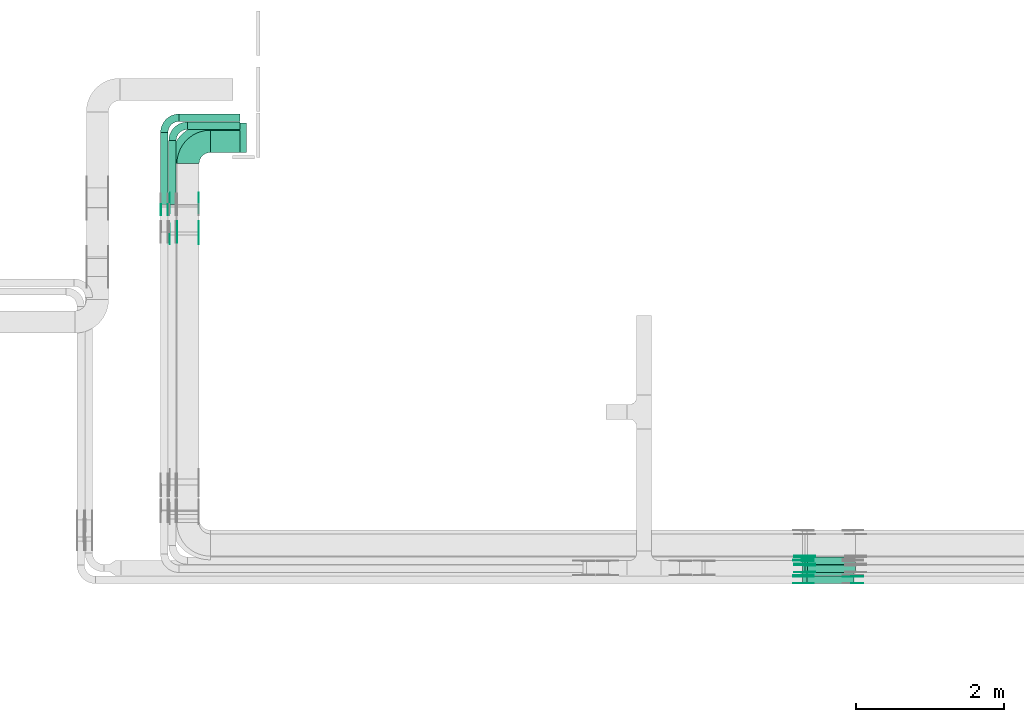
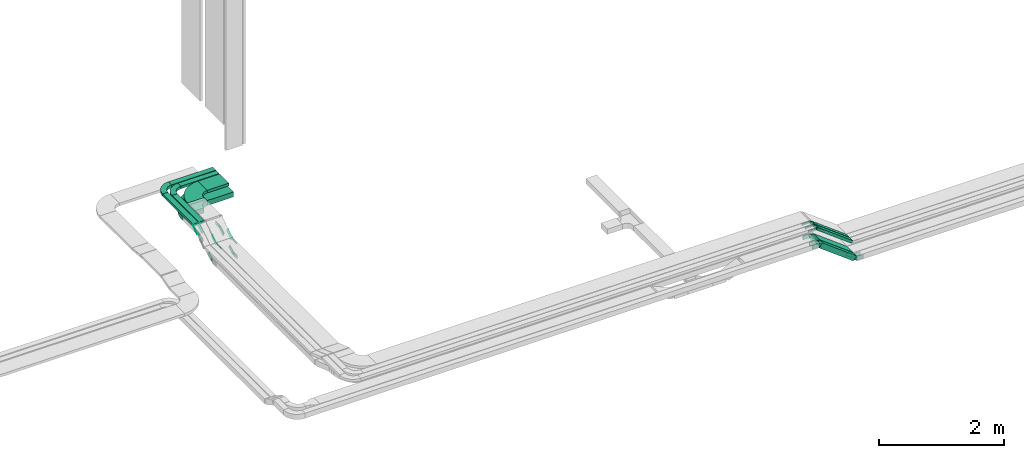
# One storey, part 8 of 27: 41 flow fittings, 10 flow segments.
"""IFC2X3 building model written with IfcOpenShell, lengths in millimetres."""

from ifc_helpers import new_model, entity, si_unit, converted_unit, derived_unit, direction, frame, frame_2d, origin, origin_2d_with_axis, place, context, subcontext, project, spatial, polyline, circle_curve, parameter, trimmed, segment, composite_curve, rectangle, outline, extrude, source, transform, mapped, material, type_object, type_shapes, element, save


model = new_model("IFC2X3")

# Units and contexts
model_context = context("Model", 3, precision=0.01, world=origin(), true_north=direction((6.12303176911189e-17, 1.0)))
body_context = subcontext(model_context, "Body", "Model", "MODEL_VIEW")
ifc_project = project(units=[si_unit("LENGTHUNIT", "METRE", prefix="MILLI"), si_unit("AREAUNIT", "SQUARE_METRE"), si_unit("VOLUMEUNIT", "CUBIC_METRE"), converted_unit("PLANEANGLEUNIT", "DEGREE", entity("IfcRatioMeasure", 0.0174532925199433), si_unit("PLANEANGLEUNIT", "RADIAN"), dimensions=[0, 0, 0, 0, 0, 0, 0]), si_unit("MASSUNIT", "GRAM", prefix="KILO"), derived_unit("MASSDENSITYUNIT", [(si_unit("MASSUNIT", "GRAM", prefix="KILO"), 1), (si_unit("LENGTHUNIT", "METRE"), -3)]), derived_unit("MOMENTOFINERTIAUNIT", [(si_unit("LENGTHUNIT", "METRE"), 4)]), si_unit("TIMEUNIT", "SECOND"), si_unit("FREQUENCYUNIT", "HERTZ"), si_unit("THERMODYNAMICTEMPERATUREUNIT", "DEGREE_CELSIUS"), derived_unit("THERMALTRANSMITTANCEUNIT", [(si_unit("MASSUNIT", "GRAM", prefix="KILO"), 1), (si_unit("THERMODYNAMICTEMPERATUREUNIT", "KELVIN"), -1), (si_unit("TIMEUNIT", "SECOND"), -3)]), derived_unit("VOLUMETRICFLOWRATEUNIT", [(si_unit("LENGTHUNIT", "METRE"), 3), (si_unit("TIMEUNIT", "SECOND"), -1)]), derived_unit("MASSFLOWRATEUNIT", [(si_unit("MASSUNIT", "GRAM", prefix="KILO"), 1), (si_unit("TIMEUNIT", "SECOND"), -1)]), derived_unit("ROTATIONALFREQUENCYUNIT", [(si_unit("TIMEUNIT", "SECOND"), -1)]), si_unit("ELECTRICCURRENTUNIT", "AMPERE"), si_unit("ELECTRICVOLTAGEUNIT", "VOLT"), si_unit("POWERUNIT", "WATT"), si_unit("FORCEUNIT", "NEWTON", prefix="KILO"), si_unit("ILLUMINANCEUNIT", "LUX"), si_unit("LUMINOUSFLUXUNIT", "LUMEN"), si_unit("LUMINOUSINTENSITYUNIT", "CANDELA"), derived_unit("USERDEFINED", [(si_unit("MASSUNIT", "GRAM", prefix="KILO"), -1), (si_unit("LENGTHUNIT", "METRE"), -2), (si_unit("TIMEUNIT", "SECOND"), 3), (si_unit("LUMINOUSFLUXUNIT", "LUMEN"), 1)]), derived_unit("LINEARVELOCITYUNIT", [(si_unit("LENGTHUNIT", "METRE"), 1), (si_unit("TIMEUNIT", "SECOND"), -1)]), si_unit("PRESSUREUNIT", "PASCAL"), derived_unit("USERDEFINED", [(si_unit("LENGTHUNIT", "METRE"), -2), (si_unit("MASSUNIT", "GRAM", prefix="KILO"), 1), (si_unit("TIMEUNIT", "SECOND"), -2)]), derived_unit("LINEARFORCEUNIT", [(si_unit("MASSUNIT", "GRAM", prefix="KILO"), 1), (si_unit("LENGTHUNIT", "METRE"), 1), (si_unit("TIMEUNIT", "SECOND"), -2), (si_unit("LENGTHUNIT", "METRE"), -1)]), derived_unit("PLANARFORCEUNIT", [(si_unit("MASSUNIT", "GRAM", prefix="KILO"), 1), (si_unit("LENGTHUNIT", "METRE"), 1), (si_unit("TIMEUNIT", "SECOND"), -2), (si_unit("LENGTHUNIT", "METRE"), -2)])], contexts=[model_context])

# Site, building, storey
site_placement = place(None, origin())
site = spatial("IfcSite", under=ifc_project, at=site_placement, CompositionType="ELEMENT")
building_placement = place(site_placement, origin())
building = spatial("IfcBuilding", under=site, at=building_placement, CompositionType="ELEMENT")
storey_placement = place(building_placement, origin())
storey = spatial("IfcBuildingStorey", under=building, at=storey_placement, CompositionType="ELEMENT", Elevation=0.0)

# Flow segments
cable_carrier_segment_type = type_object("IfcCableCarrierSegmentType", PredefinedType="CABLETRAYSEGMENT")
flow_segment_1_placement = place(storey_placement, frame((23829.86, 8250.0, 2621.54)))
element("IfcFlowSegment", 1, at=flow_segment_1_placement, inside=storey, type_object=cable_carrier_segment_type, context=body_context, shape_type="SweptSolid", body=[
    extrude(rectangle(XDim=100.000000000001, YDim=100.000000000001, at=frame_2d((0.0, 0.0), x_axis=(0.0, 1.0))), frame((30.09, 50.0, 516.98), z_axis=(0.79863551004726, 0.0, -0.601815023152092), x_axis=(0.0, 1.0, 0.0)), (0.0, 0.0, 1.0), 792.683776055081),
])
flow_segment_2_placement = place(storey_placement, frame((23829.86, 8360.0, 2621.54)))
element("IfcFlowSegment", 2, at=flow_segment_2_placement, inside=storey, type_object=cable_carrier_segment_type, context=body_context, shape_type="SweptSolid", body=[
    extrude(rectangle(XDim=99.9999999999992, YDim=200.0, at=frame_2d((0.0, 0.0), x_axis=(0.0, 1.0))), frame((30.09, 100.0, 516.98), z_axis=(0.798635510047449, 0.0, -0.601815023151841), x_axis=(0.0, 1.0, 0.0)), (0.0, 0.0, 1.0), 792.683776055017),
])
flow_segment_3_placement = place(storey_placement, frame((23864.5, 8400.0, 2861.48)))
element("IfcFlowSegment", 3, at=flow_segment_3_placement, inside=storey, type_object=cable_carrier_segment_type, context=body_context, shape_type="SweptSolid", body=[
    extrude(rectangle(XDim=49.9999999999957, YDim=100.000000000001, at=frame_2d((0.0, 0.0), x_axis=(0.0, 1.0))), frame((15.05, 50.0, 507.08), z_axis=(0.798635510047288, 0.0, -0.601815023152055), x_axis=(0.0, 1.0, 0.0)), (0.0, 0.0, 1.0), 809.413542030208),
])
flow_segment_4_placement = place(storey_placement, frame((23864.5, 8510.0, 2861.48)))
element("IfcFlowSegment", 4, at=flow_segment_4_placement, inside=storey, type_object=cable_carrier_segment_type, context=body_context, shape_type="SweptSolid", body=[
    extrude(rectangle(XDim=49.9999999999974, YDim=100.000000000001, at=frame_2d((0.0, 0.0), x_axis=(0.0, 1.0))), frame((15.05, 50.0, 507.08), z_axis=(0.798635510047365, 0.0, -0.601815023151953), x_axis=(0.0, 1.0, 0.0)), (0.0, 0.0, 1.0), 809.413542030358),
])
flow_segment_5_placement = place(storey_placement, frame((15851.0, 14057.56, 3450.0)))
element("IfcFlowSegment", 5, at=flow_segment_5_placement, inside=storey, type_object=cable_carrier_segment_type, context=body_context, shape_type="SweptSolid", body=[
    extrude(rectangle(XDim=399.000000000009, YDim=300.000000000001, at=origin_2d_with_axis()), frame((199.5, 150.0, 0.0)), (0.0, 0.0, 1.0), 49.9999999999989),
])
flow_segment_6_placement = place(storey_placement, frame((15290.0, 13356.57, 3450.0)))
element("IfcFlowSegment", 6, at=flow_segment_6_placement, inside=storey, type_object=cable_carrier_segment_type, context=body_context, shape_type="SweptSolid", body=[
    extrude(rectangle(XDim=859.993317234152, YDim=99.9999999999989, at=origin_2d_with_axis()), frame((50.0, 430.0, 0.0), z_axis=(0.0, 0.0, 1.0), x_axis=(0.0, 1.0, 0.0)), (0.0, 0.0, 1.0), 49.9999999999995),
])
flow_segment_7_placement = place(storey_placement, frame((15541.0, 14367.56, 3450.0)))
element("IfcFlowSegment", 7, at=flow_segment_7_placement, inside=storey, type_object=cable_carrier_segment_type, context=body_context, shape_type="SweptSolid", body=[
    extrude(rectangle(XDim=709.000000000006, YDim=99.9999999999989, at=origin_2d_with_axis()), frame((354.5, 50.0, 0.0)), (0.0, 0.0, 1.0), 49.9999999999995),
])
flow_segment_8_placement = place(storey_placement, frame((15180.0, 13356.57, 3450.0)))
element("IfcFlowSegment", 8, at=flow_segment_8_placement, inside=storey, type_object=cable_carrier_segment_type, context=body_context, shape_type="SweptSolid", body=[
    extrude(rectangle(XDim=969.993317234148, YDim=99.9999999999989, at=origin_2d_with_axis()), frame((50.0, 485.0, 0.0), z_axis=(0.0, 0.0, 1.0), x_axis=(0.0, 1.0, 0.0)), (0.0, 0.0, 1.0), 50.0),
])
flow_segment_9_placement = place(storey_placement, frame((15431.0, 14477.56, 3450.0)))
element("IfcFlowSegment", 9, at=flow_segment_9_placement, inside=storey, type_object=cable_carrier_segment_type, context=body_context, shape_type="SweptSolid", body=[
    extrude(rectangle(XDim=819.000000000007, YDim=99.9999999999989, at=origin_2d_with_axis()), frame((409.5, 50.0, 0.0)), (0.0, 0.0, 1.0), 49.9999999999995),
])
flow_segment_10_placement = place(storey_placement, frame((15851.0, 14057.56, 3200.0)))
element("IfcFlowSegment", 10, at=flow_segment_10_placement, inside=storey, type_object=cable_carrier_segment_type, context=body_context, shape_type="SweptSolid", body=[
    extrude(rectangle(XDim=489.000000000008, YDim=400.0, at=origin_2d_with_axis()), frame((244.5, 200.0, 0.0)), (0.0, 0.0, 1.0), 100.0),
])

# Flow fittings
ifc_material_1 = material()
cable_carrier_fitting_type_1 = type_object("IfcCableCarrierFittingType", Name="470_DKC_S5_Variable Angle Elbow 0-45:-", PredefinedType="NOTDEFINED", material=ifc_material_1)
shared_shape_1 = source(origin(), body_context, "Body", "SweptSolid", [
    extrude(outline(composite_curve([segment(polyline([(-150.75, -300.25), (-149.75, -300.25)]), True, "CONTINUOUS"), segment(trimmed(circle_curve(frame_2d((-149.75, 149.75), x_axis=(0.0, -1.0)), 450.0), [parameter(0.0)], [parameter(90.0000000000001)], True, "PARAMETER"), True, "CONTINUOUS"), segment(polyline([(300.25, 149.75), (300.25, 150.75)]), True, "CONTINUOUS"), segment(polyline([(300.25, 150.75), (0.25, 150.75)]), True, "CONTINUOUS"), segment(polyline([(0.25, 150.75), (0.25, 149.75)]), True, "CONTINUOUS"), segment(trimmed(circle_curve(frame_2d((-149.75, 149.75), x_axis=(0.0, -1.0)), 150.0), [parameter(0.0)], [parameter(90.0000000000001)], True, "PARAMETER"), False, "CONTINUOUS"), segment(polyline([(-149.75, -0.25), (-150.75, -0.25)]), True, "CONTINUOUS"), segment(polyline([(-150.75, -0.25), (-150.75, -300.25)]), True, "CONTINUOUS")], self_intersect=False)), frame((-150.25, 150.25, -25.0)), (0.0, 0.0, 1.0), 49.9999999999974),
])
type_shapes(cable_carrier_fitting_type_1, [shared_shape_1])
flow_fitting_1_placement = place(storey_placement, frame((15550.0, 14207.56, 3475.0), z_axis=(0.0, 0.0, 1.0), x_axis=(-1.0, 0.0, 0.0)))
element("IfcFlowFitting", 11, at=flow_fitting_1_placement, inside=storey, type_object=cable_carrier_fitting_type_1, material=ifc_material_1, Name="470_DKC_S5_Variable Angle Elbow 0-45:-", ObjectType="470_DKC_S5_Variable Angle Elbow 0-45:-", context=body_context, shape_type="MappedRepresentation", body=[
    mapped(shared_shape_1, transform((0.0, 0.0, 0.0), scale=1.0)),
])
cable_carrier_fitting_type_2 = type_object("IfcCableCarrierFittingType", Name="470_DKC_S5_Variable Angle Elbow 0-45:-", PredefinedType="NOTDEFINED", material=ifc_material_1)
shared_shape_2 = source(origin(), body_context, "Body", "SweptSolid", [
    extrude(outline(composite_curve([segment(polyline([(-100.75, -150.25), (-99.75, -150.25)]), True, "CONTINUOUS"), segment(trimmed(circle_curve(frame_2d((-99.75, 99.75), x_axis=(0.0, -1.0)), 250.0), [parameter(0.0)], [parameter(90.0000000000001)], True, "PARAMETER"), True, "CONTINUOUS"), segment(polyline([(150.25, 99.75), (150.25, 100.75)]), True, "CONTINUOUS"), segment(polyline([(150.25, 100.75), (50.25, 100.75)]), True, "CONTINUOUS"), segment(polyline([(50.25, 100.75), (50.25, 99.75)]), True, "CONTINUOUS"), segment(trimmed(circle_curve(frame_2d((-99.75, 99.75), x_axis=(0.0, -1.0)), 150.0), [parameter(0.0)], [parameter(90.0000000000001)], True, "PARAMETER"), False, "CONTINUOUS"), segment(polyline([(-99.75, -50.25), (-100.75, -50.25)]), True, "CONTINUOUS"), segment(polyline([(-100.75, -50.25), (-100.75, -150.25)]), True, "CONTINUOUS")], self_intersect=False)), frame((-100.25, 100.25, -25.0)), (0.0, 0.0, 1.0), 49.9999999999997),
])
type_shapes(cable_carrier_fitting_type_2, [shared_shape_2])
for number, where, z_axis, x_axis, name in (
    (12, (15340.0, 14417.56, 3475.0), (0.0, 0.0, 1.0), (-1.0, 0.0, 0.0), "470_DKC_S5_Variable Angle Elbow 0-45:-"),
    (13, (15230.0, 14527.56, 3475.0), (0.0, 0.0, 1.0), (-1.0, 0.0, 0.0), "470_DKC_S5_Variable Angle Elbow 0-45:-"),
):
    element("IfcFlowFitting", number, at=place(storey_placement, frame(where, z_axis=z_axis, x_axis=x_axis)), inside=storey, type_object=cable_carrier_fitting_type_2, material=ifc_material_1, Name=name, ObjectType="470_DKC_S5_Variable Angle Elbow 0-45:-", context=body_context, shape_type="MappedRepresentation", body=[
        mapped(shared_shape_2, transform((0.0, 0.0, 0.0), scale=1.0)),
    ])
ifc_material_2 = material(Name="G")
cable_carrier_fitting_type_3 = type_object("IfcCableCarrierFittingType", PredefinedType="NOTDEFINED", material=ifc_material_2)
shared_shape_3 = source(origin(), body_context, "Body", "SweptSolid", [
    extrude(outline(composite_curve([segment(trimmed(circle_curve(frame_2d((-44.59, 0.0), x_axis=(1.0, 0.0)), 12.5), [parameter(90.0000000000007)], [parameter(270.0)], True, "PARAMETER"), True, "CONTINUOUS"), segment(polyline([(-44.59, -12.5), (-33.09, -12.5)]), True, "CONTINUOUS"), segment(polyline([(-33.09, -12.5), (-31.23, -14.5)]), True, "CONTINUOUS"), segment(polyline([(-31.23, -14.5), (108.91, -14.5)]), True, "CONTINUOUS"), segment(polyline([(108.91, -14.5), (108.91, 14.5)]), True, "CONTINUOUS"), segment(polyline([(108.91, 14.5), (-31.23, 14.5)]), True, "CONTINUOUS"), segment(polyline([(-31.23, 14.5), (-33.09, 12.5)]), True, "CONTINUOUS"), segment(polyline([(-33.09, 12.5), (-44.59, 12.5)]), True, "CONTINUOUS")], self_intersect=False)), frame((44.59, 0.0, 0.0), z_axis=(0.0, 0.0, -1.0), x_axis=(1.0, 0.0, 0.0)), (0.0, 0.0, -1.0), 2.0),
])
type_shapes(cable_carrier_fitting_type_3, [shared_shape_3])
flow_fitting_2_placement = place(storey_placement, frame((15273.46, 13347.25, 3475.0), z_axis=(1.0, 0.0, 0.0), x_axis=(0.0, -0.848048096156981, -0.529919264232316)))
element("IfcFlowFitting", 14, at=flow_fitting_2_placement, inside=storey, type_object=cable_carrier_fitting_type_3, material=ifc_material_2, context=body_context, shape_type="MappedRepresentation", body=[
    mapped(shared_shape_3, transform((0.0, 0.0, 0.0), scale=1.0)),
])
cable_carrier_fitting_type_4 = type_object("IfcCableCarrierFittingType", PredefinedType="NOTDEFINED", material=ifc_material_2)
type_shapes(cable_carrier_fitting_type_4, [shared_shape_3])
flow_fitting_3_placement = place(storey_placement, frame((15404.54, 12995.18, 3255.0), z_axis=(-1.0, 0.0, 0.0), x_axis=(0.0, -1.0, 0.0)))
element("IfcFlowFitting", 15, at=flow_fitting_3_placement, inside=storey, type_object=cable_carrier_fitting_type_4, material=ifc_material_2, context=body_context, shape_type="MappedRepresentation", body=[
    mapped(shared_shape_3, transform((0.0, 0.0, 0.0), scale=1.0)),
])
flow_fitting_4_placement = place(storey_placement, frame((15693.46, 12995.18, 3255.0), z_axis=(1.0, 0.0, 0.0), x_axis=(0.0, 0.848048096156905, 0.529919264232438)))
element("IfcFlowFitting", 16, at=flow_fitting_4_placement, inside=storey, type_object=cable_carrier_fitting_type_3, material=ifc_material_2, context=body_context, shape_type="MappedRepresentation", body=[
    mapped(shared_shape_3, transform((0.0, 0.0, 0.0), scale=1.0)),
])
for number, where, z_axis, x_axis in (
    (17, (23871.0, 8624.54, 3375.0), (0.0, -1.0, 0.0), (-1.0, 0.0, 0.0)),
    (18, (23871.0, 8514.54, 3375.0), (0.0, -1.0, 0.0), (-1.0, 0.0, 0.0)),
):
    element("IfcFlowFitting", number, at=place(storey_placement, frame(where, z_axis=z_axis, x_axis=x_axis)), inside=storey, type_object=cable_carrier_fitting_type_4, material=ifc_material_2, context=body_context, shape_type="MappedRepresentation", body=[
        mapped(shared_shape_3, transform((0.0, 0.0, 0.0), scale=1.0)),
    ])
flow_fitting_5_placement = place(storey_placement, frame((23871.0, 8603.46, 3375.0), z_axis=(0.0, 1.0, 0.0), x_axis=(0.798635510047374, 0.0, -0.601815023151941)))
element("IfcFlowFitting", 19, at=flow_fitting_5_placement, inside=storey, type_object=cable_carrier_fitting_type_3, material=ifc_material_2, context=body_context, shape_type="MappedRepresentation", body=[
    mapped(shared_shape_3, transform((0.0, 0.0, 0.0), scale=1.0)),
])
flow_fitting_6_placement = place(storey_placement, frame((23871.0, 8404.54, 3375.0), z_axis=(0.0, -1.0, 0.0), x_axis=(-1.0, 0.0, 0.0)))
element("IfcFlowFitting", 20, at=flow_fitting_6_placement, inside=storey, type_object=cable_carrier_fitting_type_4, material=ifc_material_2, context=body_context, shape_type="MappedRepresentation", body=[
    mapped(shared_shape_3, transform((0.0, 0.0, 0.0), scale=1.0)),
])
flow_fitting_7_placement = place(storey_placement, frame((23871.0, 8493.46, 3375.0), z_axis=(0.0, 1.0, 0.0), x_axis=(0.798635510047285, 0.0, -0.601815023152059)))
element("IfcFlowFitting", 21, at=flow_fitting_7_placement, inside=storey, type_object=cable_carrier_fitting_type_3, material=ifc_material_2, context=body_context, shape_type="MappedRepresentation", body=[
    mapped(shared_shape_3, transform((0.0, 0.0, 0.0), scale=1.0)),
])
cable_carrier_fitting_type_5 = type_object("IfcCableCarrierFittingType", PredefinedType="NOTDEFINED", material=ifc_material_2)
shared_shape_4 = source(origin(), body_context, "Body", "SweptSolid", [
    extrude(outline(composite_curve([segment(trimmed(circle_curve(frame_2d((-44.59, 0.0), x_axis=(1.0, 0.0)), 12.5), [parameter(90.0000000000007)], [parameter(270.0)], True, "PARAMETER"), True, "CONTINUOUS"), segment(polyline([(-44.59, -12.5), (-33.09, -12.5)]), True, "CONTINUOUS"), segment(polyline([(-33.09, -12.5), (-31.23, -14.5)]), True, "CONTINUOUS"), segment(polyline([(-31.23, -14.5), (108.91, -14.5)]), True, "CONTINUOUS"), segment(polyline([(108.91, -14.5), (108.91, 14.5)]), True, "CONTINUOUS"), segment(polyline([(108.91, 14.5), (-31.23, 14.5)]), True, "CONTINUOUS"), segment(polyline([(-31.23, 14.5), (-33.09, 12.5)]), True, "CONTINUOUS"), segment(polyline([(-33.09, 12.5), (-44.59, 12.5)]), True, "CONTINUOUS")], self_intersect=False)), frame((44.59, 0.0, 0.0)), (0.0, 0.0, 1.0), 2.0),
])
type_shapes(cable_carrier_fitting_type_5, [shared_shape_4])
flow_fitting_8_placement = place(storey_placement, frame((15186.54, 13347.25, 3475.0), z_axis=(-1.0, 0.0, 0.0), x_axis=(0.0, -0.848048096156981, -0.529919264232316)))
element("IfcFlowFitting", 22, at=flow_fitting_8_placement, inside=storey, type_object=cable_carrier_fitting_type_5, material=ifc_material_2, context=body_context, shape_type="MappedRepresentation", body=[
    mapped(shared_shape_4, transform((0.0, 0.0, 0.0), scale=1.0)),
])
cable_carrier_fitting_type_6 = type_object("IfcCableCarrierFittingType", PredefinedType="NOTDEFINED", material=ifc_material_2)
type_shapes(cable_carrier_fitting_type_6, [shared_shape_4])
flow_fitting_9_placement = place(storey_placement, frame((15695.46, 12995.18, 3255.0), z_axis=(1.0, 0.0, 0.0), x_axis=(0.0, -1.0, 0.0)))
element("IfcFlowFitting", 23, at=flow_fitting_9_placement, inside=storey, type_object=cable_carrier_fitting_type_6, material=ifc_material_2, context=body_context, shape_type="MappedRepresentation", body=[
    mapped(shared_shape_4, transform((0.0, 0.0, 0.0), scale=1.0)),
])
for number, where, z_axis, x_axis in (
    (24, (15406.54, 12995.18, 3255.0), (-1.0, 0.0, 0.0), (0.0, 0.848048096156905, 0.529919264232438)),
    (25, (23871.0, 8626.54, 3375.0), (0.0, -1.0, 0.0), (0.798635510047512, 0.0, -0.601815023151758)),
):
    element("IfcFlowFitting", number, at=place(storey_placement, frame(where, z_axis=z_axis, x_axis=x_axis)), inside=storey, type_object=cable_carrier_fitting_type_5, material=ifc_material_2, context=body_context, shape_type="MappedRepresentation", body=[
        mapped(shared_shape_4, transform((0.0, 0.0, 0.0), scale=1.0)),
    ])
flow_fitting_10_placement = place(storey_placement, frame((23871.0, 8605.46, 3375.0), z_axis=(0.0, 1.0, 0.0), x_axis=(-1.0, 0.0, 0.0)))
element("IfcFlowFitting", 26, at=flow_fitting_10_placement, inside=storey, type_object=cable_carrier_fitting_type_6, material=ifc_material_2, context=body_context, shape_type="MappedRepresentation", body=[
    mapped(shared_shape_4, transform((0.0, 0.0, 0.0), scale=1.0)),
])
flow_fitting_11_placement = place(storey_placement, frame((23871.0, 8516.54, 3375.0), z_axis=(0.0, -1.0, 0.0), x_axis=(0.798635510047374, 0.0, -0.601815023151941)))
element("IfcFlowFitting", 27, at=flow_fitting_11_placement, inside=storey, type_object=cable_carrier_fitting_type_5, material=ifc_material_2, context=body_context, shape_type="MappedRepresentation", body=[
    mapped(shared_shape_4, transform((0.0, 0.0, 0.0), scale=1.0)),
])
flow_fitting_12_placement = place(storey_placement, frame((23871.0, 8495.46, 3375.0), z_axis=(0.0, 1.0, 0.0), x_axis=(-1.0, 0.0, 0.0)))
element("IfcFlowFitting", 28, at=flow_fitting_12_placement, inside=storey, type_object=cable_carrier_fitting_type_6, material=ifc_material_2, context=body_context, shape_type="MappedRepresentation", body=[
    mapped(shared_shape_4, transform((0.0, 0.0, 0.0), scale=1.0)),
])
flow_fitting_13_placement = place(storey_placement, frame((23871.0, 8406.54, 3375.0), z_axis=(0.0, -1.0, 0.0), x_axis=(0.798635510047285, 0.0, -0.601815023152059)))
element("IfcFlowFitting", 29, at=flow_fitting_13_placement, inside=storey, type_object=cable_carrier_fitting_type_5, material=ifc_material_2, context=body_context, shape_type="MappedRepresentation", body=[
    mapped(shared_shape_4, transform((0.0, 0.0, 0.0), scale=1.0)),
])
cable_carrier_fitting_type_7 = type_object("IfcCableCarrierFittingType", PredefinedType="NOTDEFINED", material=ifc_material_2)
shared_shape_5 = source(origin(), body_context, "Body", "SweptSolid", [
    extrude(outline(composite_curve([segment(trimmed(circle_curve(frame_2d((-41.47, 0.0), x_axis=(1.0, 0.0)), 25.0), [parameter(90.0000000000007)], [parameter(270.0)], True, "PARAMETER"), True, "CONTINUOUS"), segment(polyline([(-41.47, -25.0), (-29.97, -25.0)]), True, "CONTINUOUS"), segment(polyline([(-29.97, -25.0), (-28.1, -38.5)]), True, "CONTINUOUS"), segment(polyline([(-28.1, -38.5), (99.53, -38.5)]), True, "CONTINUOUS"), segment(polyline([(99.53, -38.5), (99.53, 38.5)]), True, "CONTINUOUS"), segment(polyline([(99.53, 38.5), (-28.1, 38.5)]), True, "CONTINUOUS"), segment(polyline([(-28.1, 38.5), (-29.97, 25.0)]), True, "CONTINUOUS"), segment(polyline([(-29.97, 25.0), (-41.47, 25.0)]), True, "CONTINUOUS")], self_intersect=False)), frame((41.47, 0.0, 0.0), z_axis=(0.0, 0.0, -1.0), x_axis=(1.0, 0.0, 0.0)), (0.0, 0.0, -1.0), 2.0),
])
type_shapes(cable_carrier_fitting_type_7, [shared_shape_5])
flow_fitting_14_placement = place(storey_placement, frame((23844.72, 8345.46, 3150.0), z_axis=(0.0, 1.0, 0.0), x_axis=(0.798635510047293, 0.0, -0.601815023152048)))
element("IfcFlowFitting", 30, at=flow_fitting_14_placement, inside=storey, type_object=cable_carrier_fitting_type_7, material=ifc_material_2, context=body_context, shape_type="MappedRepresentation", body=[
    mapped(shared_shape_5, transform((0.0, 0.0, 0.0), scale=1.0)),
])
cable_carrier_fitting_type_8 = type_object("IfcCableCarrierFittingType", PredefinedType="NOTDEFINED", material=ifc_material_2)
type_shapes(cable_carrier_fitting_type_8, [shared_shape_5])
flow_fitting_15_placement = place(storey_placement, frame((23844.72, 8256.54, 3150.0), z_axis=(0.0, -1.0, 0.0), x_axis=(-1.0, 0.0, 0.0)))
element("IfcFlowFitting", 31, at=flow_fitting_15_placement, inside=storey, type_object=cable_carrier_fitting_type_8, material=ifc_material_2, context=body_context, shape_type="MappedRepresentation", body=[
    mapped(shared_shape_5, transform((0.0, 0.0, 0.0), scale=1.0)),
])
flow_fitting_16_placement = place(storey_placement, frame((24508.25, 8254.54, 2650.0), z_axis=(0.0, -1.0, 0.0), x_axis=(1.0, 0.0, 0.0)))
element("IfcFlowFitting", 32, at=flow_fitting_16_placement, inside=storey, type_object=cable_carrier_fitting_type_7, material=ifc_material_2, context=body_context, shape_type="MappedRepresentation", body=[
    mapped(shared_shape_5, transform((0.0, 0.0, 0.0), scale=1.0)),
])
flow_fitting_17_placement = place(storey_placement, frame((24508.25, 8343.46, 2650.0), z_axis=(0.0, 1.0, 0.0), x_axis=(-0.79863551004728, 0.0, 0.601815023152065)))
element("IfcFlowFitting", 33, at=flow_fitting_17_placement, inside=storey, type_object=cable_carrier_fitting_type_8, material=ifc_material_2, context=body_context, shape_type="MappedRepresentation", body=[
    mapped(shared_shape_5, transform((0.0, 0.0, 0.0), scale=1.0)),
])
for number, where, z_axis, x_axis in (
    (34, (23844.72, 8574.54, 3150.0), (0.0, -1.0, 0.0), (-1.0, 0.0, 0.0)),
    (35, (23844.72, 8364.54, 3150.0), (0.0, -1.0, 0.0), (-1.0, 0.0, 0.0)),
):
    element("IfcFlowFitting", number, at=place(storey_placement, frame(where, z_axis=z_axis, x_axis=x_axis)), inside=storey, type_object=cable_carrier_fitting_type_7, material=ifc_material_2, context=body_context, shape_type="MappedRepresentation", body=[
        mapped(shared_shape_5, transform((0.0, 0.0, 0.0), scale=1.0)),
    ])
flow_fitting_18_placement = place(storey_placement, frame((23844.72, 8553.46, 3150.0), z_axis=(0.0, 1.0, 0.0), x_axis=(0.798635510047463, 0.0, -0.601815023151822)))
element("IfcFlowFitting", 36, at=flow_fitting_18_placement, inside=storey, type_object=cable_carrier_fitting_type_8, material=ifc_material_2, context=body_context, shape_type="MappedRepresentation", body=[
    mapped(shared_shape_5, transform((0.0, 0.0, 0.0), scale=1.0)),
])
flow_fitting_19_placement = place(storey_placement, frame((15304.54, 13377.15, 3250.0), z_axis=(-1.0, 0.0, 0.0), x_axis=(0.0, 1.0, 0.0)))
element("IfcFlowFitting", 37, at=flow_fitting_19_placement, inside=storey, type_object=cable_carrier_fitting_type_7, material=ifc_material_2, context=body_context, shape_type="MappedRepresentation", body=[
    mapped(shared_shape_5, transform((0.0, 0.0, 0.0), scale=1.0)),
])
flow_fitting_20_placement = place(storey_placement, frame((15693.46, 13377.15, 3250.0), z_axis=(1.0, 0.0, 0.0), x_axis=(0.0, -0.848048096156376, -0.529919264233284)))
element("IfcFlowFitting", 38, at=flow_fitting_20_placement, inside=storey, type_object=cable_carrier_fitting_type_8, material=ifc_material_2, context=body_context, shape_type="MappedRepresentation", body=[
    mapped(shared_shape_5, transform((0.0, 0.0, 0.0), scale=1.0)),
])
flow_fitting_21_placement = place(storey_placement, frame((15304.54, 12961.07, 2990.0), z_axis=(-1.0, 0.0, 0.0), x_axis=(0.0, -1.0, 0.0)))
element("IfcFlowFitting", 39, at=flow_fitting_21_placement, inside=storey, type_object=cable_carrier_fitting_type_7, material=ifc_material_2, context=body_context, shape_type="MappedRepresentation", body=[
    mapped(shared_shape_5, transform((0.0, 0.0, 0.0), scale=1.0)),
])
flow_fitting_22_placement = place(storey_placement, frame((15693.46, 12961.07, 2990.0), z_axis=(1.0, 0.0, 0.0), x_axis=(0.0, 0.848048096156366, 0.529919264233302)))
element("IfcFlowFitting", 40, at=flow_fitting_22_placement, inside=storey, type_object=cable_carrier_fitting_type_8, material=ifc_material_2, context=body_context, shape_type="MappedRepresentation", body=[
    mapped(shared_shape_5, transform((0.0, 0.0, 0.0), scale=1.0)),
])
cable_carrier_fitting_type_9 = type_object("IfcCableCarrierFittingType", PredefinedType="NOTDEFINED", material=ifc_material_2)
shared_shape_6 = source(origin(), body_context, "Body", "SweptSolid", [
    extrude(outline(composite_curve([segment(trimmed(circle_curve(frame_2d((-41.47, 0.0), x_axis=(1.0, 0.0)), 25.0), [parameter(90.0000000000007)], [parameter(270.0)], True, "PARAMETER"), True, "CONTINUOUS"), segment(polyline([(-41.47, -25.0), (-29.97, -25.0)]), True, "CONTINUOUS"), segment(polyline([(-29.97, -25.0), (-28.1, -38.5)]), True, "CONTINUOUS"), segment(polyline([(-28.1, -38.5), (99.53, -38.5)]), True, "CONTINUOUS"), segment(polyline([(99.53, -38.5), (99.53, 38.5)]), True, "CONTINUOUS"), segment(polyline([(99.53, 38.5), (-28.1, 38.5)]), True, "CONTINUOUS"), segment(polyline([(-28.1, 38.5), (-29.97, 25.0)]), True, "CONTINUOUS"), segment(polyline([(-29.97, 25.0), (-41.47, 25.0)]), True, "CONTINUOUS")], self_intersect=False)), frame((41.47, 0.0, 0.0)), (0.0, 0.0, 1.0), 2.0),
])
type_shapes(cable_carrier_fitting_type_9, [shared_shape_6])
flow_fitting_23_placement = place(storey_placement, frame((23844.72, 8254.54, 3150.0), z_axis=(0.0, -1.0, 0.0), x_axis=(0.798635510047293, 0.0, -0.601815023152048)))
element("IfcFlowFitting", 41, at=flow_fitting_23_placement, inside=storey, type_object=cable_carrier_fitting_type_9, material=ifc_material_2, context=body_context, shape_type="MappedRepresentation", body=[
    mapped(shared_shape_6, transform((0.0, 0.0, 0.0), scale=1.0)),
])
cable_carrier_fitting_type_10 = type_object("IfcCableCarrierFittingType", PredefinedType="NOTDEFINED", material=ifc_material_2)
type_shapes(cable_carrier_fitting_type_10, [shared_shape_6])
flow_fitting_24_placement = place(storey_placement, frame((23844.72, 8343.46, 3150.0), z_axis=(0.0, 1.0, 0.0), x_axis=(-1.0, 0.0, 0.0)))
element("IfcFlowFitting", 42, at=flow_fitting_24_placement, inside=storey, type_object=cable_carrier_fitting_type_10, material=ifc_material_2, context=body_context, shape_type="MappedRepresentation", body=[
    mapped(shared_shape_6, transform((0.0, 0.0, 0.0), scale=1.0)),
])
flow_fitting_25_placement = place(storey_placement, frame((24508.25, 8345.46, 2650.0), z_axis=(0.0, 1.0, 0.0), x_axis=(1.0, 0.0, 0.0)))
element("IfcFlowFitting", 43, at=flow_fitting_25_placement, inside=storey, type_object=cable_carrier_fitting_type_9, material=ifc_material_2, context=body_context, shape_type="MappedRepresentation", body=[
    mapped(shared_shape_6, transform((0.0, 0.0, 0.0), scale=1.0)),
])
flow_fitting_26_placement = place(storey_placement, frame((23844.72, 8576.54, 3150.0), z_axis=(0.0, -1.0, 0.0), x_axis=(0.798635510047464, 0.0, -0.601815023151821)))
element("IfcFlowFitting", 44, at=flow_fitting_26_placement, inside=storey, type_object=cable_carrier_fitting_type_10, material=ifc_material_2, context=body_context, shape_type="MappedRepresentation", body=[
    mapped(shared_shape_6, transform((0.0, 0.0, 0.0), scale=1.0)),
])
flow_fitting_27_placement = place(storey_placement, frame((23844.72, 8555.46, 3150.0), z_axis=(0.0, 1.0, 0.0), x_axis=(-1.0, 0.0, 0.0)))
element("IfcFlowFitting", 45, at=flow_fitting_27_placement, inside=storey, type_object=cable_carrier_fitting_type_9, material=ifc_material_2, context=body_context, shape_type="MappedRepresentation", body=[
    mapped(shared_shape_6, transform((0.0, 0.0, 0.0), scale=1.0)),
])
flow_fitting_28_placement = place(storey_placement, frame((23844.72, 8366.54, 3150.0), z_axis=(0.0, -1.0, 0.0), x_axis=(0.798635510047463, 0.0, -0.601815023151822)))
element("IfcFlowFitting", 46, at=flow_fitting_28_placement, inside=storey, type_object=cable_carrier_fitting_type_10, material=ifc_material_2, context=body_context, shape_type="MappedRepresentation", body=[
    mapped(shared_shape_6, transform((0.0, 0.0, 0.0), scale=1.0)),
])
flow_fitting_29_placement = place(storey_placement, frame((15695.46, 13377.15, 3250.0), z_axis=(1.0, 0.0, 0.0), x_axis=(0.0, 1.0, 0.0)))
element("IfcFlowFitting", 47, at=flow_fitting_29_placement, inside=storey, type_object=cable_carrier_fitting_type_9, material=ifc_material_2, context=body_context, shape_type="MappedRepresentation", body=[
    mapped(shared_shape_6, transform((0.0, 0.0, 0.0), scale=1.0)),
])
flow_fitting_30_placement = place(storey_placement, frame((15306.54, 13377.15, 3250.0), z_axis=(-1.0, 0.0, 0.0), x_axis=(0.0, -0.848048096156376, -0.529919264233284)))
element("IfcFlowFitting", 48, at=flow_fitting_30_placement, inside=storey, type_object=cable_carrier_fitting_type_10, material=ifc_material_2, context=body_context, shape_type="MappedRepresentation", body=[
    mapped(shared_shape_6, transform((0.0, 0.0, 0.0), scale=1.0)),
])
flow_fitting_31_placement = place(storey_placement, frame((15695.46, 12961.07, 2990.0), z_axis=(1.0, 0.0, 0.0), x_axis=(0.0, -1.0, 0.0)))
element("IfcFlowFitting", 49, at=flow_fitting_31_placement, inside=storey, type_object=cable_carrier_fitting_type_9, material=ifc_material_2, context=body_context, shape_type="MappedRepresentation", body=[
    mapped(shared_shape_6, transform((0.0, 0.0, 0.0), scale=1.0)),
])
flow_fitting_32_placement = place(storey_placement, frame((15306.54, 12961.07, 2990.0), z_axis=(-1.0, 0.0, 0.0), x_axis=(0.0, 0.848048096156366, 0.529919264233302)))
element("IfcFlowFitting", 50, at=flow_fitting_32_placement, inside=storey, type_object=cable_carrier_fitting_type_10, material=ifc_material_2, context=body_context, shape_type="MappedRepresentation", body=[
    mapped(shared_shape_6, transform((0.0, 0.0, 0.0), scale=1.0)),
])
cable_carrier_fitting_type_11 = type_object("IfcCableCarrierFittingType", Name="470_DKC_S5_Variable Angle Elbow 0-45:-", PredefinedType="NOTDEFINED", material=ifc_material_1)
shared_shape_7 = source(origin(), body_context, "Body", "SweptSolid", [
    extrude(outline(composite_curve([segment(polyline([(-175.75, -375.25), (-174.75, -375.25)]), True, "CONTINUOUS"), segment(trimmed(circle_curve(frame_2d((-174.75, 174.75), x_axis=(0.0, -1.0)), 550.0), [parameter(0.0)], [parameter(90.0)], True, "PARAMETER"), True, "CONTINUOUS"), segment(polyline([(375.25, 174.75), (375.25, 175.75)]), True, "CONTINUOUS"), segment(polyline([(375.25, 175.75), (-24.75, 175.75)]), True, "CONTINUOUS"), segment(polyline([(-24.75, 175.75), (-24.75, 174.75)]), True, "CONTINUOUS"), segment(trimmed(circle_curve(frame_2d((-174.75, 174.75), x_axis=(0.0, -1.0)), 150.0), [parameter(0.0)], [parameter(90.0)], True, "PARAMETER"), False, "CONTINUOUS"), segment(polyline([(-174.75, 24.75), (-175.75, 24.75)]), True, "CONTINUOUS"), segment(polyline([(-175.75, 24.75), (-175.75, -375.25)]), True, "CONTINUOUS")], self_intersect=False)), frame((-175.25, 175.25, -50.0)), (0.0, 0.0, 1.0), 99.9999999999956),
])
type_shapes(cable_carrier_fitting_type_11, [shared_shape_7])
flow_fitting_33_placement = place(storey_placement, frame((15500.0, 14257.56, 3250.0), z_axis=(0.0, 0.0, 1.0), x_axis=(-1.0, 0.0, 0.0)))
element("IfcFlowFitting", 51, at=flow_fitting_33_placement, inside=storey, type_object=cable_carrier_fitting_type_11, material=ifc_material_1, Name="470_DKC_S5_Variable Angle Elbow 0-45:-", ObjectType="470_DKC_S5_Variable Angle Elbow 0-45:-", context=body_context, shape_type="MappedRepresentation", body=[
    mapped(shared_shape_7, transform((0.0, 0.0, 0.0), scale=1.0)),
])

save(model, "model.ifc")
